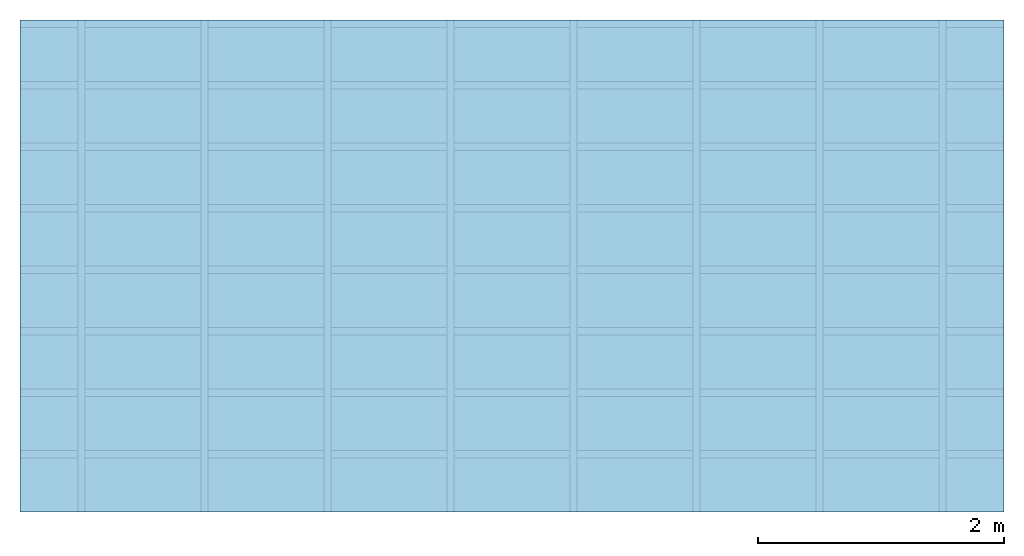
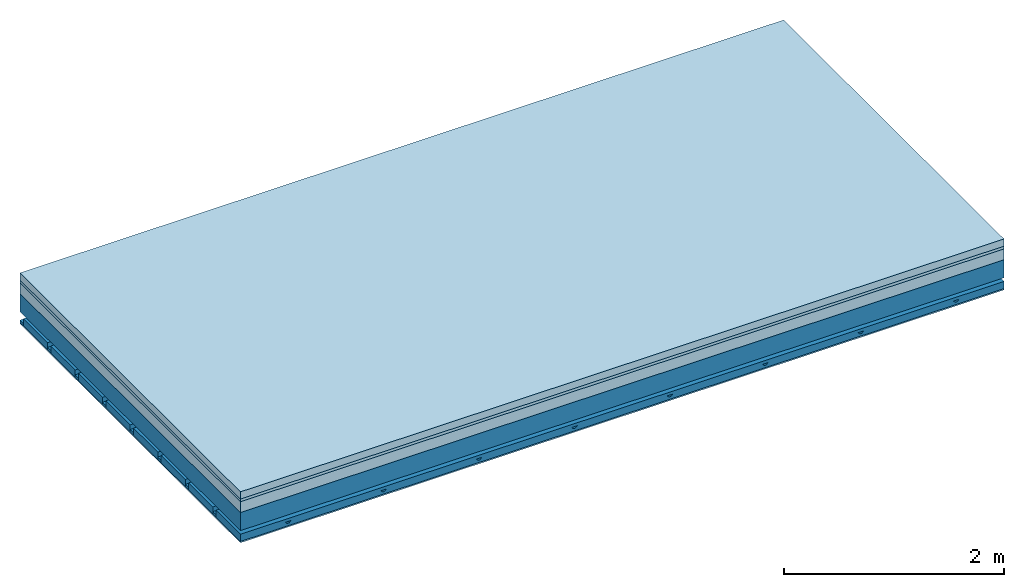
# One storey: 4 members, 4 plates, 1 element without a shape of its own.
"""IFC4 building model written with IfcOpenShell, lengths in metres."""

from ifc_helpers import new_model, si_unit, derived_unit, direction, frame, frame_2d, origin, origin_with_axes, place, context, project, spatial, polyline, rectangle, outline, extrude, material, layer, layer_set, type_object, element, aggregate, save


model = new_model("IFC4")

# Units and contexts
plan_context = context("Plan", 3, precision=1e-05, world=origin(), true_north=direction((0.0, 1.0)))
model_context = context("Model", 3, precision=1e-05, world=origin(), true_north=direction((0.0, 1.0)))
ifc_project = project(units=[si_unit("LENGTHUNIT", "METRE"), derived_unit("SOUNDPRESSUREUNIT", [(si_unit("PRESSUREUNIT", "PASCAL", prefix="MICRO"), 0)]), si_unit("ENERGYUNIT", "JOULE", prefix="MEGA"), si_unit("MASSUNIT", "GRAM", prefix="KILO"), derived_unit("THERMALTRANSMITTANCEUNIT", [(si_unit("POWERUNIT", "WATT"), 1), (si_unit("AREAUNIT", "SQUARE_METRE"), -1), (si_unit("THERMODYNAMICTEMPERATUREUNIT", "KELVIN"), -1)]), derived_unit("AREADENSITYUNIT", [(si_unit("MASSUNIT", "GRAM", prefix="KILO"), 1), (si_unit("AREAUNIT", "SQUARE_METRE"), -1)]), derived_unit("USERDEFINED", [(si_unit("ENERGYUNIT", "JOULE", prefix="MEGA"), 1), (si_unit("AREAUNIT", "SQUARE_METRE"), -1)])], contexts=[plan_context, model_context])

# Site, building, storey
site = spatial("IfcSite", under=ifc_project)
building_placement = place(None, origin())
building = spatial("IfcBuilding", under=site, at=building_placement)
storey_placement = place(building_placement, origin())
storey = spatial("IfcBuildingStorey", under=building, at=storey_placement)

# Slab, members, plates
ifc_material_1 = material(Name="Cement screed", Category="04.006")
ifc_layer_1 = layer(ifc_material_1, 0.08, Name="On-material")
ifc_material_2 = material()
ifc_layer_2 = layer(ifc_material_2, 0.03, Name="Impact sound insulation")
ifc_material_3 = material(Category="03.011")
ifc_layer_3 = layer(ifc_material_3, 0.12, Name="on Supporting structure")
ifc_layer_4 = layer(None, 0.2, Name="Supporting structure")
ifc_material_4 = material(Name="no composite action")
ifc_layer_5 = layer(ifc_material_4, 0.0, Name="Bond")
ifc_layer_6 = layer(None, 0.093, Name="Coupling")
ifc_layer_7 = layer(None, 0.027, Name="Battens / profiles")
ifc_material_5 = material(Name="Plasterboard type A", Category="03.008")
ifc_layer_8 = layer(ifc_material_5, 0.015, Name="Ceiling covering 1st layer")
ifc_material_6 = material(Name="joints", Category="04.017")
ifc_layer_9 = layer(ifc_material_6, 0.0, Name="Surface / treatment")
ifc_layer_set = layer_set([ifc_layer_1, ifc_layer_2, ifc_layer_3, ifc_layer_4, ifc_layer_5, ifc_layer_6, ifc_layer_7, ifc_layer_8, ifc_layer_9])
slab_type = type_object("IfcSlabType", Name="A1283", PredefinedType="NOTDEFINED", material=ifc_layer_set)
slab_placement = place(None, frame((0.0, 0.0, 0.0), z_axis=(0.0, 0.0, -1.0), x_axis=(1.0, 0.0, 0.0)))
slab = element("IfcSlab", 1, at=slab_placement, inside=storey, type_object=slab_type, material=ifc_layer_set, Name="Slab #1")
ifc_material_7 = material()
member_1_placement = place(slab_placement, origin())
member_1 = element("IfcMember", 2, at=member_1_placement, material=ifc_material_7, Name="Supporting structure", context=plan_context, shape_type="SweptSolid", body=[
    extrude(rectangle(XDim=1.0, YDim=0.2, at=frame_2d((0.5, 0.1), x_axis=(1.0, 0.0))), frame((0.0, 4.0, 0.23), z_axis=(0.0, -1.0, 0.0), x_axis=(1.0, 0.0, 0.0)), (0.0, 0.0, 1.0), 4.0),
    extrude(rectangle(XDim=1.0, YDim=0.2, at=frame_2d((0.5, 0.1), x_axis=(1.0, 0.0))), frame((1.0, 4.0, 0.23), z_axis=(0.0, -1.0, 0.0), x_axis=(1.0, 0.0, 0.0)), (0.0, 0.0, 1.0), 4.0),
    extrude(rectangle(XDim=1.0, YDim=0.2, at=frame_2d((0.5, 0.1), x_axis=(1.0, 0.0))), frame((2.0, 4.0, 0.23), z_axis=(0.0, -1.0, 0.0), x_axis=(1.0, 0.0, 0.0)), (0.0, 0.0, 1.0), 4.0),
    extrude(rectangle(XDim=1.0, YDim=0.2, at=frame_2d((0.5, 0.1), x_axis=(1.0, 0.0))), frame((3.0, 4.0, 0.23), z_axis=(0.0, -1.0, 0.0), x_axis=(1.0, 0.0, 0.0)), (0.0, 0.0, 1.0), 4.0),
    extrude(rectangle(XDim=1.0, YDim=0.2, at=frame_2d((0.5, 0.1), x_axis=(1.0, 0.0))), frame((4.0, 4.0, 0.23), z_axis=(0.0, -1.0, 0.0), x_axis=(1.0, 0.0, 0.0)), (0.0, 0.0, 1.0), 4.0),
    extrude(rectangle(XDim=1.0, YDim=0.2, at=frame_2d((0.5, 0.1), x_axis=(1.0, 0.0))), frame((5.0, 4.0, 0.23), z_axis=(0.0, -1.0, 0.0), x_axis=(1.0, 0.0, 0.0)), (0.0, 0.0, 1.0), 4.0),
    extrude(rectangle(XDim=1.0, YDim=0.2, at=frame_2d((0.5, 0.1), x_axis=(1.0, 0.0))), frame((6.0, 4.0, 0.23), z_axis=(0.0, -1.0, 0.0), x_axis=(1.0, 0.0, 0.0)), (0.0, 0.0, 1.0), 4.0),
    extrude(rectangle(XDim=1.0, YDim=0.2, at=frame_2d((0.5, 0.1), x_axis=(1.0, 0.0))), frame((7.0, 4.0, 0.23), z_axis=(0.0, -1.0, 0.0), x_axis=(1.0, 0.0, 0.0)), (0.0, 0.0, 1.0), 4.0),
])
ifc_material_8 = material()
member_2_placement = place(slab_placement, origin())
member_2 = element("IfcMember", 3, at=member_2_placement, material=ifc_material_8, Name="Coupling", context=plan_context, shape_type="SweptSolid", body=[
    extrude(outline(polyline([(0.0, 0.0), (0.06, 0.0), (0.04, 0.02), (0.02, 0.02), (0.0, 0.0)])), frame((0.47, 4.0, 0.503), z_axis=(0.0, -1.0, 0.0), x_axis=(1.0, 0.0, 0.0)), (0.0, 0.0, 1.0), 4.0),
    extrude(outline(polyline([(0.0, 0.0), (0.06, 0.0), (0.04, 0.02), (0.02, 0.02), (0.0, 0.0)])), frame((1.47, 4.0, 0.503), z_axis=(0.0, -1.0, 0.0), x_axis=(1.0, 0.0, 0.0)), (0.0, 0.0, 1.0), 4.0),
    extrude(outline(polyline([(0.0, 0.0), (0.06, 0.0), (0.04, 0.02), (0.02, 0.02), (0.0, 0.0)])), frame((2.47, 4.0, 0.503), z_axis=(0.0, -1.0, 0.0), x_axis=(1.0, 0.0, 0.0)), (0.0, 0.0, 1.0), 4.0),
    extrude(outline(polyline([(0.0, 0.0), (0.06, 0.0), (0.04, 0.02), (0.02, 0.02), (0.0, 0.0)])), frame((3.47, 4.0, 0.503), z_axis=(0.0, -1.0, 0.0), x_axis=(1.0, 0.0, 0.0)), (0.0, 0.0, 1.0), 4.0),
    extrude(outline(polyline([(0.0, 0.0), (0.06, 0.0), (0.04, 0.02), (0.02, 0.02), (0.0, 0.0)])), frame((4.47, 4.0, 0.503), z_axis=(0.0, -1.0, 0.0), x_axis=(1.0, 0.0, 0.0)), (0.0, 0.0, 1.0), 4.0),
    extrude(outline(polyline([(0.0, 0.0), (0.06, 0.0), (0.04, 0.02), (0.02, 0.02), (0.0, 0.0)])), frame((5.47, 4.0, 0.503), z_axis=(0.0, -1.0, 0.0), x_axis=(1.0, 0.0, 0.0)), (0.0, 0.0, 1.0), 4.0),
    extrude(outline(polyline([(0.0, 0.0), (0.06, 0.0), (0.04, 0.02), (0.02, 0.02), (0.0, 0.0)])), frame((6.47, 4.0, 0.503), z_axis=(0.0, -1.0, 0.0), x_axis=(1.0, 0.0, 0.0)), (0.0, 0.0, 1.0), 4.0),
    extrude(outline(polyline([(0.0, 0.0), (0.06, 0.0), (0.04, 0.02), (0.02, 0.02), (0.0, 0.0)])), frame((7.47, 4.0, 0.503), z_axis=(0.0, -1.0, 0.0), x_axis=(1.0, 0.0, 0.0)), (0.0, 0.0, 1.0), 4.0),
])
ifc_material_9 = material()
member_3_placement = place(slab_placement, origin())
member_3 = element("IfcMember", 4, at=member_3_placement, material=ifc_material_9, Name="Battens / profiles", context=plan_context, shape_type="SweptSolid", body=[
    extrude(rectangle(XDim=0.06, YDim=0.027, at=frame_2d((0.03, 0.0135), x_axis=(1.0, 0.0))), frame((0.0, 0.0, 0.523), z_axis=(1.0, 0.0, 0.0), x_axis=(0.0, 1.0, 0.0)), (0.0, 0.0, 1.0), 8.0),
    extrude(rectangle(XDim=0.06, YDim=0.027, at=frame_2d((0.03, 0.0135), x_axis=(1.0, 0.0))), frame((0.0, 0.5, 0.523), z_axis=(1.0, 0.0, 0.0), x_axis=(0.0, 1.0, 0.0)), (0.0, 0.0, 1.0), 8.0),
    extrude(rectangle(XDim=0.06, YDim=0.027, at=frame_2d((0.03, 0.0135), x_axis=(1.0, 0.0))), frame((0.0, 1.0, 0.523), z_axis=(1.0, 0.0, 0.0), x_axis=(0.0, 1.0, 0.0)), (0.0, 0.0, 1.0), 8.0),
    extrude(rectangle(XDim=0.06, YDim=0.027, at=frame_2d((0.03, 0.0135), x_axis=(1.0, 0.0))), frame((0.0, 1.5, 0.523), z_axis=(1.0, 0.0, 0.0), x_axis=(0.0, 1.0, 0.0)), (0.0, 0.0, 1.0), 8.0),
    extrude(rectangle(XDim=0.06, YDim=0.027, at=frame_2d((0.03, 0.0135), x_axis=(1.0, 0.0))), frame((0.0, 2.0, 0.523), z_axis=(1.0, 0.0, 0.0), x_axis=(0.0, 1.0, 0.0)), (0.0, 0.0, 1.0), 8.0),
    extrude(rectangle(XDim=0.06, YDim=0.027, at=frame_2d((0.03, 0.0135), x_axis=(1.0, 0.0))), frame((0.0, 2.5, 0.523), z_axis=(1.0, 0.0, 0.0), x_axis=(0.0, 1.0, 0.0)), (0.0, 0.0, 1.0), 8.0),
    extrude(rectangle(XDim=0.06, YDim=0.027, at=frame_2d((0.03, 0.0135), x_axis=(1.0, 0.0))), frame((0.0, 3.0, 0.523), z_axis=(1.0, 0.0, 0.0), x_axis=(0.0, 1.0, 0.0)), (0.0, 0.0, 1.0), 8.0),
    extrude(rectangle(XDim=0.06, YDim=0.027, at=frame_2d((0.03, 0.0135), x_axis=(1.0, 0.0))), frame((0.0, 3.5, 0.523), z_axis=(1.0, 0.0, 0.0), x_axis=(0.0, 1.0, 0.0)), (0.0, 0.0, 1.0), 8.0),
])
ifc_material_10 = material()
member_4_placement = place(slab_placement, origin())
member_4 = element("IfcMember", 5, at=member_4_placement, material=ifc_material_10, Name="Cavity", context=plan_context, shape_type="SweptSolid", body=[
    extrude(rectangle(XDim=0.44, YDim=0.08, at=frame_2d((0.22, 0.04), x_axis=(1.0, 0.0))), frame((0.0, 0.06, 0.47), z_axis=(1.0, 0.0, 0.0), x_axis=(0.0, 1.0, 0.0)), (0.0, 0.0, 1.0), 8.0),
    extrude(rectangle(XDim=0.44, YDim=0.08, at=frame_2d((0.22, 0.04), x_axis=(1.0, 0.0))), frame((0.0, 0.56, 0.47), z_axis=(1.0, 0.0, 0.0), x_axis=(0.0, 1.0, 0.0)), (0.0, 0.0, 1.0), 8.0),
    extrude(rectangle(XDim=0.44, YDim=0.08, at=frame_2d((0.22, 0.04), x_axis=(1.0, 0.0))), frame((0.0, 1.06, 0.47), z_axis=(1.0, 0.0, 0.0), x_axis=(0.0, 1.0, 0.0)), (0.0, 0.0, 1.0), 8.0),
    extrude(rectangle(XDim=0.44, YDim=0.08, at=frame_2d((0.22, 0.04), x_axis=(1.0, 0.0))), frame((0.0, 1.56, 0.47), z_axis=(1.0, 0.0, 0.0), x_axis=(0.0, 1.0, 0.0)), (0.0, 0.0, 1.0), 8.0),
    extrude(rectangle(XDim=0.44, YDim=0.08, at=frame_2d((0.22, 0.04), x_axis=(1.0, 0.0))), frame((0.0, 2.06, 0.47), z_axis=(1.0, 0.0, 0.0), x_axis=(0.0, 1.0, 0.0)), (0.0, 0.0, 1.0), 8.0),
    extrude(rectangle(XDim=0.44, YDim=0.08, at=frame_2d((0.22, 0.04), x_axis=(1.0, 0.0))), frame((0.0, 2.56, 0.47), z_axis=(1.0, 0.0, 0.0), x_axis=(0.0, 1.0, 0.0)), (0.0, 0.0, 1.0), 8.0),
    extrude(rectangle(XDim=0.44, YDim=0.08, at=frame_2d((0.22, 0.04), x_axis=(1.0, 0.0))), frame((0.0, 3.06, 0.47), z_axis=(1.0, 0.0, 0.0), x_axis=(0.0, 1.0, 0.0)), (0.0, 0.0, 1.0), 8.0),
    extrude(rectangle(XDim=0.44, YDim=0.08, at=frame_2d((0.22, 0.04), x_axis=(1.0, 0.0))), frame((0.0, 3.56, 0.47), z_axis=(1.0, 0.0, 0.0), x_axis=(0.0, 1.0, 0.0)), (0.0, 0.0, 1.0), 8.0),
])
plate_1_placement = place(slab_placement, origin())
plate_1 = element("IfcPlate", 6, at=plate_1_placement, material=ifc_material_1, Name="On-material", context=plan_context, shape_type="SweptSolid", body=[
    extrude(rectangle(XDim=8.0, YDim=4.0, at=frame_2d((4.0, 2.0), x_axis=(1.0, 0.0))), origin_with_axes(), (0.0, 0.0, 1.0), 0.08),
])
plate_2_placement = place(slab_placement, origin())
plate_2 = element("IfcPlate", 7, at=plate_2_placement, material=ifc_material_2, Name="Impact sound insulation", context=plan_context, shape_type="SweptSolid", body=[
    extrude(rectangle(XDim=8.0, YDim=4.0, at=frame_2d((4.0, 2.0), x_axis=(1.0, 0.0))), frame((0.0, 0.0, 0.08), z_axis=(0.0, 0.0, 1.0), x_axis=(1.0, 0.0, 0.0)), (0.0, 0.0, 1.0), 0.03),
])
plate_3_placement = place(slab_placement, origin())
plate_3 = element("IfcPlate", 8, at=plate_3_placement, material=ifc_material_3, Name="on Supporting structure", context=plan_context, shape_type="SweptSolid", body=[
    extrude(rectangle(XDim=8.0, YDim=4.0, at=frame_2d((4.0, 2.0), x_axis=(1.0, 0.0))), frame((0.0, 0.0, 0.11), z_axis=(0.0, 0.0, 1.0), x_axis=(1.0, 0.0, 0.0)), (0.0, 0.0, 1.0), 0.12),
])
plate_4_placement = place(slab_placement, origin())
plate_4 = element("IfcPlate", 9, at=plate_4_placement, material=ifc_material_5, Name="Ceiling covering 1st layer", context=plan_context, shape_type="SweptSolid", body=[
    extrude(rectangle(XDim=8.0, YDim=4.0, at=frame_2d((4.0, 2.0), x_axis=(1.0, 0.0))), frame((0.0, 0.0, 0.55), z_axis=(0.0, 0.0, 1.0), x_axis=(1.0, 0.0, 0.0)), (0.0, 0.0, 1.0), 0.015),
])
aggregate(slab, [plate_1, plate_2, plate_3, member_1, member_2, member_3, member_4, plate_4])

save(model, "model.ifc")
